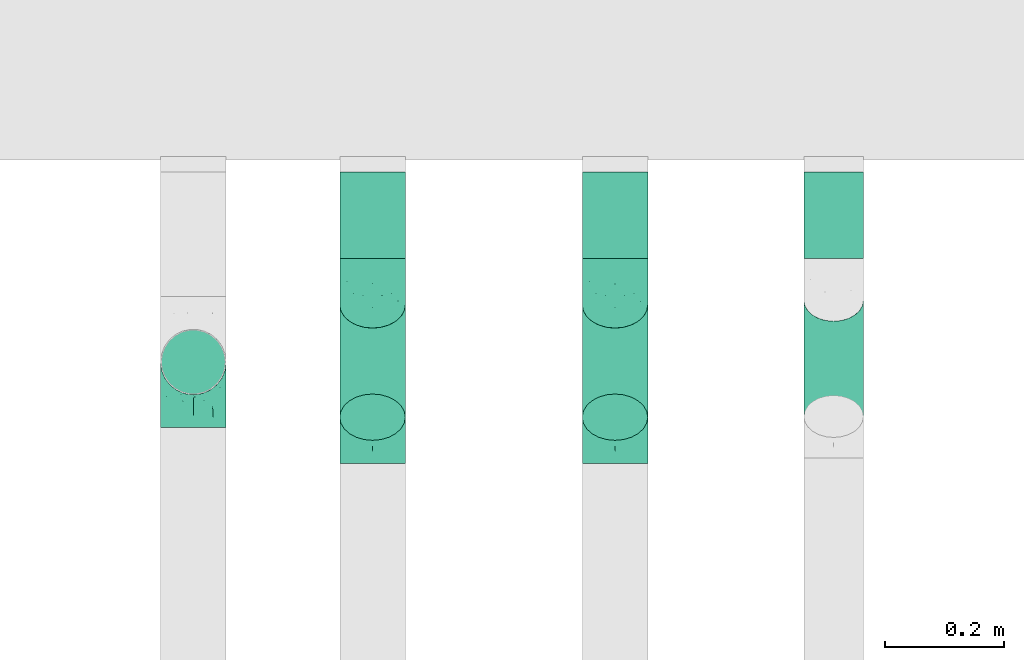
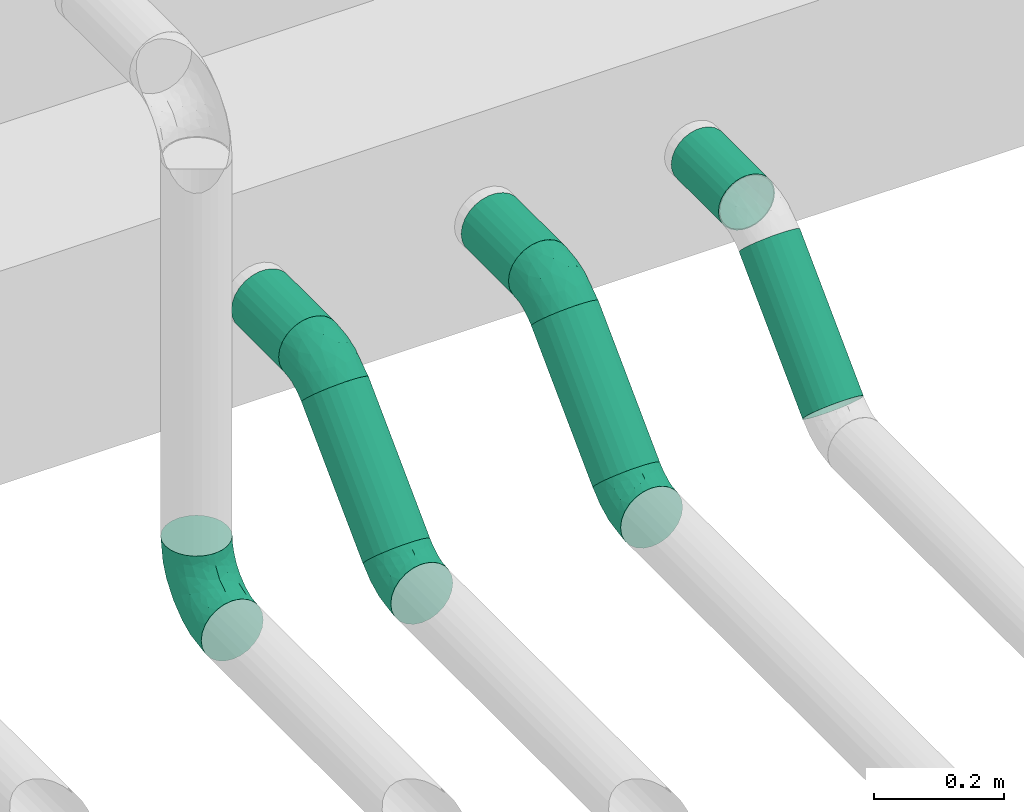
# One storey, part 54 of 91: 6 flow segments, 5 flow fittings.
"""IFC2X3 building model written with IfcOpenShell, lengths in millimetres."""

import ifcopenshell
import ifcopenshell.guid

model = None  # the IFC model being written
_history = None  # IfcOwnerHistory: only IFC2X3 demands one
_inside = {}  # id of a spatial element -> (the spatial element, [elements in it])
_under = {}  # id of a project, library or spatial element -> (it, [spatial elements below it])
_declared = {}  # id of a project -> (the project, [libraries it declares])
_typed = {}  # id of a type object -> (the type object, [elements of that type])
_made_of = {}  # id of a material, layer set ... -> (it, [elements and type objects made of it])


def new_model(schema):
    """Start an empty IFC model of exactly this schema.

    Asked for "IFC4X3", IfcOpenShell would pick the latest addendum, in which some entities
    have other attributes; the version numbers below select the first issue.
    IFC2X3 requires an IfcOwnerHistory on every rooted entity: one is made here for all.
    """
    global model, _history
    if schema == "IFC4X3":
        model = ifcopenshell.file(schema_version=(4, 3, 0, 0))
    else:
        model = ifcopenshell.file(schema=schema)
    _inside.clear()
    _under.clear()
    _declared.clear()
    _typed.clear()
    _made_of.clear()
    _history = None
    if model.schema == "IFC2X3":
        org = make("IfcOrganization", Name="unknown")
        user = make(
            "IfcPersonAndOrganization",
            ThePerson=make("IfcPerson", FamilyName="unknown"),
            TheOrganization=org,
        )
        app = make(
            "IfcApplication",
            ApplicationDeveloper=org,
            Version="unknown",
            ApplicationFullName="unknown",
            ApplicationIdentifier="unknown",
        )
        _history = make(
            "IfcOwnerHistory",
            OwningUser=user,
            OwningApplication=app,
            ChangeAction="ADDED",
            CreationDate=0,
        )
    return model


def make(cls, **values):
    """One entity of the class cls with the attributes given. An attribute that is None is left unset."""
    return model.create_entity(
        cls, **{name: value for name, value in values.items() if value is not None}
    )


def entity(cls, *values):
    """Any entity or typed value of the class cls, its attributes in the order of the schema. None: left unset."""
    e = model.create_entity(cls)
    for i, value in enumerate(values):
        if value is not None:
            e[i] = value
    return e


def rooted(cls, **values):
    """An entity with a GlobalId (a new one), such as an element, a storey or a relation."""
    return make(cls, GlobalId=ifcopenshell.guid.new(), OwnerHistory=_history, **values)


def si_unit(unit_type, name, prefix=None):
    """IfcSIUnit, for example si_unit("LENGTHUNIT", "METRE", prefix="MILLI")."""
    return make("IfcSIUnit", UnitType=unit_type, Prefix=prefix, Name=name)


def converted_unit(unit_type, name, factor, base, dimensions=None, offset=None):
    """IfcConversionBasedUnit, such as the inch: factor (a typed value) times the base unit."""
    return make(
        "IfcConversionBasedUnit"
        if offset is None
        else "IfcConversionBasedUnitWithOffset",
        ConversionOffset=offset,
        Dimensions=None
        if dimensions is None
        else entity("IfcDimensionalExponents", *dimensions),
        UnitType=unit_type,
        Name=name,
        ConversionFactor=make(
            "IfcMeasureWithUnit", ValueComponent=factor, UnitComponent=base
        ),
    )


def derived_unit(unit_type, elements):
    """IfcDerivedUnit: a product of units, each with its exponent."""
    return make(
        "IfcDerivedUnit",
        Elements=[
            make("IfcDerivedUnitElement", Unit=unit, Exponent=power)
            for unit, power in elements
        ],
        UnitType=unit_type,
    )


def assignment(units):
    """IfcUnitAssignment: the units of a project."""
    return None if units is None else make("IfcUnitAssignment", Units=units)


def point(xyz):
    """IfcCartesianPoint."""
    return None if xyz is None else make("IfcCartesianPoint", Coordinates=xyz)


def direction(xyz):
    """IfcDirection."""
    return None if xyz is None else make("IfcDirection", DirectionRatios=xyz)


def frame(location, z_axis=None, x_axis=None):
    """IfcAxis2Placement3D, a coordinate frame: its origin and axes. An axis left out is left unset."""
    return make(
        "IfcAxis2Placement3D",
        Location=point(location),
        Axis=direction(z_axis),
        RefDirection=direction(x_axis),
    )


def frame_2d(location, x_axis=None):
    """IfcAxis2Placement2D, a coordinate frame in the plane: its origin and x axis."""
    return make(
        "IfcAxis2Placement2D", Location=point(location), RefDirection=direction(x_axis)
    )


def origin_with_axes():
    """The frame at (0, 0, 0) with the z axis (0, 0, 1) and the x axis (1, 0, 0) written out."""
    return frame((0.0, 0.0, 0.0), z_axis=(0.0, 0.0, 1.0), x_axis=(1.0, 0.0, 0.0))


def origin_2d_with_axis():
    """The frame at (0, 0) in the plane with the x axis (1, 0) written out."""
    return frame_2d((0.0, 0.0), x_axis=(1.0, 0.0))


def place(relative_to, where):
    """IfcLocalPlacement: puts the frame where relative to a parent placement (None: the world)."""
    return make(
        "IfcLocalPlacement", PlacementRelTo=relative_to, RelativePlacement=where
    )


def context(
    kind, dimensions, precision=None, world=None, true_north=None, identifier=None
):
    """IfcGeometricRepresentationContext, for example the 3D "Model" context."""
    return make(
        "IfcGeometricRepresentationContext",
        ContextIdentifier=identifier,
        ContextType=kind,
        CoordinateSpaceDimension=dimensions,
        Precision=precision,
        WorldCoordinateSystem=world,
        TrueNorth=true_north,
    )


def subcontext(parent, identifier, kind, view, scale=None):
    """IfcGeometricRepresentationSubContext, for example "Body" below "Model"."""
    return make(
        "IfcGeometricRepresentationSubContext",
        ContextIdentifier=identifier,
        ContextType=kind,
        ParentContext=parent,
        TargetScale=scale,
        TargetView=view,
    )


def project(units=None, contexts=None):
    """IfcProject with its units and contexts."""
    return rooted(
        "IfcProject",
        Name="project",
        RepresentationContexts=contexts,
        UnitsInContext=assignment(units),
    )


def spatial(cls, under=None, at=None, **own):
    """A site, building, storey or space (cls), placed at a placement, below another one or the project."""
    s = rooted(cls, ObjectPlacement=at, **own)
    if under is not None:
        _under.setdefault(under.id(), (under, []))[1].append(s)
    return s


def profile(cls, at=None, kind="AREA", **sizes):
    """A parametric profile (cls). Its sizes go by their IFC names, for example OverallWidth=200.0."""
    return make(cls, ProfileType=kind, Position=at, **sizes)


def hollow_circle(**sizes):
    """IfcCircleHollowProfileDef."""
    return profile("IfcCircleHollowProfileDef", **sizes)


def extrude(swept, where, along, depth):
    """IfcExtrudedAreaSolid: the profile swept, set in the frame where, extruded along a direction by depth."""
    return make(
        "IfcExtrudedAreaSolid",
        SweptArea=swept,
        Position=where,
        ExtrudedDirection=direction(along),
        Depth=depth,
    )


def faces_of(points, faces, orient=None, outer=None):
    """IfcFace entities. A face is a list of loops; a loop is a list of indices into points, from 0.

    orient and outer hold one flag for each loop. By default every Orientation is true, the
    first loop of a face is its IfcFaceOuterBound and the others are IfcFaceBound.
    """
    made = []
    for i, loops in enumerate(faces):
        bounds = []
        for j, loop in enumerate(loops):
            is_outer = j == 0 if outer is None else outer[i][j]
            bounds.append(
                make(
                    "IfcFaceOuterBound" if is_outer else "IfcFaceBound",
                    Bound=make("IfcPolyLoop", Polygon=[points[k] for k in loop]),
                    Orientation=True if orient is None else orient[i][j],
                )
            )
        made.append(make("IfcFace", Bounds=bounds))
    return made


def open_shell(faces, orient=None, outer=None):
    """The faces of one IfcOpenShell. surface_model builds it on its shared points."""
    return ("IfcOpenShell", faces, orient, outer)


def surface_model(cls, points, shells):
    """IfcFaceBasedSurfaceModel or IfcShellBasedSurfaceModel (cls): surfaces that need not close."""
    shared = [point(p) for p in points]
    made = [make(c, CfsFaces=faces_of(shared, fs, o, b)) for c, fs, o, b in shells]
    if cls == "IfcFaceBasedSurfaceModel":
        return make(cls, FbsmFaces=made)
    return make(cls, SbsmBoundary=made)


def shape(context_of_items, identifier, shape_type, items):
    """IfcShapeRepresentation: the items that make up one representation, for example the "Body"."""
    return make(
        "IfcShapeRepresentation",
        ContextOfItems=context_of_items,
        RepresentationIdentifier=identifier,
        RepresentationType=shape_type,
        Items=items,
    )


def source(mapping_origin, context_of_items, identifier, shape_type, items):
    """IfcRepresentationMap: a shape defined once, which mapped items show again and again."""
    return make(
        "IfcRepresentationMap",
        MappingOrigin=mapping_origin,
        MappedRepresentation=shape(context_of_items, identifier, shape_type, items),
    )


def transform(
    local_origin,
    x_axis=None,
    y_axis=None,
    z_axis=None,
    scale=None,
    scale2=None,
    scale3=None,
    uniform=True,
):
    """IfcCartesianTransformationOperator3D, or its non-uniform kind. x_axis, y_axis, z_axis: its Axis1, 2, 3."""
    if uniform:
        return make(
            "IfcCartesianTransformationOperator3D",
            Axis1=direction(x_axis),
            Axis2=direction(y_axis),
            LocalOrigin=point(local_origin),
            Scale=scale,
            Axis3=direction(z_axis),
        )
    return make(
        "IfcCartesianTransformationOperator3DnonUniform",
        Axis1=direction(x_axis),
        Axis2=direction(y_axis),
        LocalOrigin=point(local_origin),
        Scale=scale,
        Axis3=direction(z_axis),
        Scale2=scale2,
        Scale3=scale3,
    )


def mapped(mapping_source, mapping_target):
    """IfcMappedItem: shows the shape of a source again, moved by a transform."""
    return make(
        "IfcMappedItem", MappingSource=mapping_source, MappingTarget=mapping_target
    )


def material(Name=None, Category=None):
    """IfcMaterial."""
    return make("IfcMaterial", Name=Name, Category=Category)


def layer(
    of_material, thickness, ventilated=None, Name=None, Category=None, Priority=None
):
    """IfcMaterialLayer: one layer of a wall or slab, of a material (None: an air gap)."""
    return make(
        "IfcMaterialLayer",
        Material=of_material,
        LayerThickness=thickness,
        IsVentilated=ventilated,
        Name=Name,
        Category=Category,
        Priority=Priority,
    )


def layer_set(layers, Name=None):
    """IfcMaterialLayerSet."""
    return make("IfcMaterialLayerSet", MaterialLayers=layers, LayerSetName=Name)


def layer_usage(for_layer_set, set_direction, sense, offset, extent=None):
    """IfcMaterialLayerSetUsage: how a layer set lies in its element."""
    return make(
        "IfcMaterialLayerSetUsage",
        ForLayerSet=for_layer_set,
        LayerSetDirection=set_direction,
        DirectionSense=sense,
        OffsetFromReferenceLine=offset,
        ReferenceExtent=extent,
    )


def made_of(thing, what):
    """Note that an element or type object is made of a material, layer set ...; save() writes the relation."""
    if what is not None:
        _made_of.setdefault(what.id(), (what, []))[1].append(thing)
    return thing


def type_object(cls, material=None, **own):
    """A type object (cls), such as IfcWallType, which elements share."""
    return made_of(rooted(cls, **own), material)


def element(
    cls,
    number,
    at=None,
    inside=None,
    cuts=None,
    type_object=None,
    material=None,
    context=None,
    identifier="Body",
    shape_type=None,
    held_by="IfcProductDefinitionShape",
    body=None,
    shapes=None,
    **own,
):
    """One element of the class cls, such as IfcWall. Its Tag is "e" and its number.

    at: its placement. inside: the storey or other place that contains it. cuts: it is an
    opening in that element (IfcRelVoidsElement). A single representation is given by context,
    identifier, shape_type and body (its items); several are given by shapes. held_by: the class
    of the entity that holds the representations. save() writes the other relations.
    """
    e = rooted(cls, Tag="e%d" % number, ObjectPlacement=at, **own)
    if body is not None:
        shapes = [shape(context, identifier, shape_type, body)]
    if shapes is not None:
        e.Representation = make(held_by, Representations=shapes)
    if inside is not None:
        _inside.setdefault(inside.id(), (inside, []))[1].append(e)
    if cuts is not None:
        rooted(
            "IfcRelVoidsElement", RelatingBuildingElement=cuts, RelatedOpeningElement=e
        )
    if type_object is not None:
        _typed.setdefault(type_object.id(), (type_object, []))[1].append(e)
    return made_of(e, material)


def aggregate(whole, parts):
    """IfcRelAggregates: a whole, such as a stair, and the parts it consists of."""
    return rooted("IfcRelAggregates", RelatingObject=whole, RelatedObjects=parts)


def save(model, path):
    """Write the relations noted so far, then the file.

    IfcRelAggregates (storeys below a building ...), IfcRelContainedInSpatialStructure (elements
    in a storey), IfcRelDefinesByType, IfcRelAssociatesMaterial and IfcRelDeclares: one each for
    every whole, place, type object, material and project.
    """
    for whole, parts in _under.values():
        aggregate(whole, parts)
    for where, things in _inside.values():
        rooted(
            "IfcRelContainedInSpatialStructure",
            RelatedElements=things,
            RelatingStructure=where,
        )
    for kind, things in _typed.values():
        rooted("IfcRelDefinesByType", RelatedObjects=things, RelatingType=kind)
    for what, things in _made_of.values():
        rooted("IfcRelAssociatesMaterial", RelatedObjects=things, RelatingMaterial=what)
    for by, libraries in _declared.values():
        rooted("IfcRelDeclares", RelatingContext=by, RelatedDefinitions=libraries)
    model.write(path)


model = new_model("IFC2X3")

# Units and contexts
model_context = context("Model", 3, precision=1e-05, world=origin_with_axes(), true_north=direction((0.0, 1.0)))
body_context = subcontext(model_context, "Body", "Model", "MODEL_VIEW")
ifc_project = project(units=[si_unit("AREAUNIT", "SQUARE_METRE"), si_unit("VOLUMEUNIT", "CUBIC_METRE", prefix="DECI"), si_unit("TIMEUNIT", "SECOND"), si_unit("THERMODYNAMICTEMPERATUREUNIT", "DEGREE_CELSIUS"), si_unit("PRESSUREUNIT", "PASCAL"), si_unit("MASSUNIT", "GRAM", prefix="KILO"), si_unit("LENGTHUNIT", "METRE", prefix="MILLI"), si_unit("POWERUNIT", "WATT"), si_unit("ELECTRICCURRENTUNIT", "AMPERE"), si_unit("ELECTRICVOLTAGEUNIT", "VOLT"), derived_unit("VOLUMETRICFLOWRATEUNIT", [(si_unit("VOLUMEUNIT", "CUBIC_METRE", prefix="DECI"), 1), (si_unit("TIMEUNIT", "SECOND"), -1)]), derived_unit("LINEARVELOCITYUNIT", [(si_unit("LENGTHUNIT", "METRE"), 1), (si_unit("TIMEUNIT", "SECOND"), -1)]), derived_unit("MASSDENSITYUNIT", [(si_unit("MASSUNIT", "GRAM", prefix="KILO"), 1), (si_unit("VOLUMEUNIT", "CUBIC_METRE"), -1)]), converted_unit("PLANEANGLEUNIT", "DEGREE", entity("IfcRatioMeasure", 0.01745), si_unit("PLANEANGLEUNIT", "RADIAN"), dimensions=[0, 0, 0, 0, 0, 0, 0])], contexts=[model_context])

# Site, building, storey
site_placement = place(None, origin_with_axes())
site = spatial("IfcSite", under=ifc_project, at=site_placement, CompositionType="ELEMENT")
building_placement = place(site_placement, origin_with_axes())
building = spatial("IfcBuilding", under=site, at=building_placement, Name="mc-building", CompositionType="ELEMENT")
storey_placement = place(building_placement, frame((0.0, 0.0, 8700.0), z_axis=(0.0, 0.0, 1.0), x_axis=(1.0, 0.0, 0.0)))
storey = spatial("IfcBuildingStorey", under=building, at=storey_placement, CompositionType="ELEMENT", Elevation=8700.0)

# Flow fitting
duct_fitting_type = type_object("IfcDuctFittingType", Name="BU", PredefinedType="BEND")
shared_shape_1 = source(origin_with_axes(), body_context, "Body", "SurfaceModel", [
    surface_model("IfcShellBasedSurfaceModel", [(-110.0, 0.0, -55.0), (-110.0, -14.23505, -53.12592), (-110.0, 14.23505, -53.12592), (-110.0, 53.12592, 14.23505), (-110.0, 27.5, -47.63139), (-110.0, 38.89087, -38.89087), (-110.0, -55.0, 0.0), (-110.0, -53.12592, 14.23505), (-110.0, -38.89087, -38.89087), (-110.0, -27.5, -47.63139), (-110.0, -53.12592, -14.23505), (-110.0, -47.63139, -27.5), (-110.0, -14.23505, 53.12592), (-110.0, 14.23505, 53.12592), (-110.0, 27.5, 47.63139), (-110.0, -47.63139, 27.5), (-110.0, -38.89087, 38.89087), (-110.0, -27.5, 47.63139), (-110.0, 0.0, 55.0), (-110.0, 55.0, 0.0), (-110.0, 53.12592, -14.23505), (-110.0, 47.63139, -27.5), (-110.0, 47.63139, 27.5), (-110.0, 38.89087, 38.89087), (-14.23505, 110.0, -53.12592), (-55.0, 110.0, 0.0), (0.0, 110.0, -55.0), (-27.5, 110.0, -47.63139), (-38.89087, 110.0, -38.89087), (-47.63139, 110.0, -27.5), (38.89087, 110.0, -38.89087), (53.12592, 110.0, 14.23505), (27.5, 110.0, -47.63139), (14.23505, 110.0, -53.12592), (47.63139, 110.0, -27.5), (53.12592, 110.0, -14.23505), (55.0, 110.0, 0.0), (-53.12592, 110.0, -14.23505), (-53.12592, 110.0, 14.23505), (-47.63139, 110.0, 27.5), (-38.89087, 110.0, 38.89087), (-27.5, 110.0, 47.63139), (0.0, 110.0, 55.0), (-14.23505, 110.0, 53.12592), (38.89087, 110.0, 38.89087), (47.63139, 110.0, 27.5), (27.5, 110.0, 47.63139), (14.23505, 110.0, 53.12592), (-64.21732, 48.68956, 43.63444), (-76.6405, 38.18013, 45.55988), (-60.44912, 32.56953, 51.94617), (-76.00813, 5.38378, 55.0), (-90.15553, 11.94394, 54.09138), (-78.5998, 26.77405, 50.81338), (-70.18771, 18.55163, 54.03432), (-75.55424, 54.2118, 32.41257), (-93.27622, 45.77614, 33.48188), (-96.12334, 22.13664, 50.81337), (-21.00813, 45.34362, 55.0), (-18.36258, 70.48427, 54.04484), (-32.04182, 59.64019, 52.24446), (-63.88653, 74.77858, 17.99134), (-74.66383, 63.08407, 19.92123), (-63.60674, 66.07878, 29.97482), (-99.597, 52.72185, 18.52927), (-93.11138, 56.59448, 10.50359), (-98.21577, 57.34403, 0.0), (-53.42855, 92.60092, 21.04759), (-88.54852, 54.8376, 21.04759), (-11.86161, 90.23965, 54.10313), (-5.38378, 76.00813, 55.0), (-57.34403, 98.21577, 0.0), (-56.64619, 93.12774, 10.22088), (-45.34362, 21.00813, 55.0), (-44.60838, 44.60838, 52.13415), (-92.68484, 35.46673, 43.63443), (-22.25266, 95.40765, 50.81337), (-35.97783, 90.61597, 43.63443), (-43.70931, 69.58671, 44.47149), (-27.23711, 77.39884, 50.81337), (-57.2828, 79.3123, 24.9774), (-58.67786, 84.31125, 16.04456), (-82.93277, 60.36161, 12.91784), (-49.88337, 54.51816, 47.224), (-74.57753, 66.83759, 9.55742), (-45.35812, 94.97281, 33.48188), (-59.18663, 88.95241, 0.0), (-51.517, 78.6292, 33.48188), (-65.14788, 80.03077, 0.0), (-56.45322, 62.06476, 39.63545), (-88.95241, 59.18663, 0.0), (-71.10913, 71.10913, 0.0), (-80.03077, 65.14788, 0.0), (-94.9309, 45.36788, -33.48188), (-93.11358, 56.60141, -10.46614), (-99.64997, 52.79499, -18.30015), (-90.20425, 36.08686, -43.63443), (-79.99933, 46.56772, -37.92748), (-76.00813, 5.38378, -55.0), (-72.75364, 19.68651, -53.60527), (-45.34362, 21.00813, -55.0), (-21.91957, 65.12078, -53.85897), (-5.38378, 76.00813, -55.0), (-21.00813, 45.34362, -55.0), (-35.41876, 92.89265, -43.63443), (-91.10309, 11.02766, -54.21832), (-45.77614, 93.27622, -33.48188), (-90.50474, 23.21022, -50.81337), (-70.92854, 33.31794, -49.51754), (-78.52933, 63.35627, -11.73997), (-24.91508, 84.05606, -50.81337), (-88.78941, 54.74452, -21.04759), (-69.59921, 57.34866, -33.48187), (-73.36422, 62.46673, -22.94182), (-63.49062, 67.59111, -28.46929), (-56.59448, 93.11138, -10.50359), (-54.8376, 88.54852, -21.04759), (-54.10679, 75.85581, -32.31867), (-57.75956, 31.09612, -52.80882), (-52.72185, 99.597, -18.52927), (-12.62913, 89.46304, -53.99097), (-34.46825, 66.46123, -50.04329), (-43.9837, 43.9837, -52.42279), (-65.78527, 72.58348, -17.68796), (-70.34468, 43.65295, -44.21951), (-57.47001, 51.99467, -44.91465), (-60.72547, 82.29174, -12.88567), (-42.34915, 74.24548, -43.63444), (-57.25194, 63.5016, -38.08211), (-80.95344, 53.56991, -29.32027), (-52.32891, 4.55257, -54.0482), (32.52942, 47.13398, -30.48571), (14.88266, 20.92917, -33.7947), (14.95561, 36.05775, -42.26543), (30.24048, 70.09027, -41.7461), (19.3559, 65.35825, -48.00507), (-70.35075, -46.44478, -19.5952), (-47.13398, -32.52942, -30.48571), (-28.49299, -30.5778, -16.4009), (-4.55257, 52.32891, -54.0482), (-22.4954, 22.4954, -53.25347), (-75.47368, -11.22546, -52.60718), (-81.32209, -51.5606, -9.98467), (-80.81763, -41.84862, -32.14655), (-70.09027, -30.24048, -41.7461), (-36.05774, -14.95561, -42.26543), (-9.15831, -10.852, -27.8997), (-65.35825, -19.3559, -48.00507), (11.22546, 75.47368, -52.60718), (3.94376, 43.9333, -50.53315), (-13.39742, 13.39743, -48.13058), (-43.9333, -3.94376, -50.53315), (49.37776, 67.29486, 0.0), (41.8609, 47.82256, -9.92641), (50.20582, 74.51695, -9.9731), (18.93131, 11.7156, -17.56239), (-27.5, -32.89419, 0.0), (-1.23348, -12.25375, -12.18106), (41.84862, 80.81763, -32.14655), (35.70604, 41.31408, -20.38235), (46.44478, 70.35075, -19.5952), (32.89419, 27.5, 0.0), (6.67262, -6.67262, 0.0), (-67.29486, -49.37776, 0.0), (-50.36265, -42.95545, -9.51562), (-5.47251, 5.47251, -39.92906), (-70.35075, -46.44478, 19.5952), (-74.51695, -50.20582, 9.9731), (-41.31407, -35.70604, 20.38235), (-47.13398, -32.52942, 30.48571), (-80.81763, -41.84862, 32.14655), (-4.55257, 52.32891, 54.0482), (11.22546, 75.47368, 52.60718), (-43.9333, -3.94376, 50.53315), (-65.35825, -19.3559, 48.00507), (-36.05774, -14.95561, 42.26543), (-70.09027, -30.24048, 41.7461), (-11.7156, -18.93131, 17.56239), (30.5778, 28.49299, 16.4009), (12.25375, 1.23348, 12.18106), (51.5606, 81.32209, 9.98467), (42.95545, 50.36265, 9.51562), (-75.47368, -11.22546, 52.60718), (-52.32891, 4.55257, 54.0482), (3.94376, 43.9333, 50.53315), (-22.4954, 22.4954, 53.25347), (-13.39742, 13.39743, 48.13058), (10.852, 9.15831, 27.8997), (-20.92916, -14.88266, 33.79469), (-47.82256, -41.8609, 9.92641), (32.52942, 47.13398, 30.48571), (46.44478, 70.35075, 19.5952), (41.84862, 80.81763, 32.14655), (30.24048, 70.09027, 41.7461), (19.3559, 65.35825, 48.00507), (14.95561, 36.05775, 42.26543), (-5.47251, 5.47251, 39.92906)], [open_shell([[[0, 1, 2]], [[2, 3, 4]], [[4, 3, 5]], [[2, 6, 7]], [[8, 6, 9]], [[1, 9, 6]], [[10, 6, 11]], [[8, 11, 6]], [[6, 2, 1]], [[12, 13, 14]], [[15, 2, 7]], [[16, 17, 2]], [[2, 17, 12]], [[12, 18, 13]], [[19, 20, 3]], [[5, 3, 21]], [[20, 21, 3]], [[22, 3, 2]], [[23, 22, 2]], [[12, 14, 2]], [[2, 14, 23]], [[15, 16, 2]], [[24, 25, 26]], [[27, 25, 24]], [[25, 28, 29]], [[28, 25, 27]], [[30, 26, 31]], [[26, 30, 32]], [[32, 33, 26]], [[34, 31, 35]], [[31, 34, 30]], [[35, 31, 36]], [[29, 37, 25]], [[38, 39, 26]], [[39, 40, 26]], [[41, 42, 40]], [[42, 26, 40]], [[42, 41, 43]], [[26, 44, 45]], [[31, 26, 45]], [[26, 46, 44]], [[47, 46, 26]], [[42, 47, 26]], [[25, 38, 26]], [[48, 49, 50]], [[18, 51, 52]], [[53, 54, 50]], [[55, 56, 49]], [[56, 22, 23]], [[13, 57, 14]], [[58, 59, 60]], [[61, 62, 63]], [[3, 64, 65]], [[53, 52, 54]], [[3, 65, 66]], [[67, 39, 38]], [[56, 68, 64]], [[65, 64, 68]], [[69, 59, 70]], [[38, 71, 72]], [[73, 58, 74]], [[75, 49, 56]], [[76, 69, 43]], [[53, 57, 52]], [[77, 78, 79]], [[41, 76, 43]], [[43, 69, 42]], [[55, 68, 56]], [[23, 14, 75]], [[76, 77, 79]], [[80, 67, 81]], [[62, 82, 68]], [[60, 78, 83]], [[62, 84, 82]], [[85, 77, 40]], [[81, 67, 72]], [[86, 72, 71]], [[87, 85, 67]], [[61, 81, 88]], [[77, 41, 40]], [[78, 77, 87]], [[23, 75, 56]], [[83, 89, 48]], [[85, 40, 39]], [[62, 68, 55]], [[89, 87, 63]], [[83, 48, 50]], [[57, 75, 14]], [[49, 75, 53]], [[67, 85, 39]], [[87, 77, 85]], [[63, 62, 55]], [[89, 55, 48]], [[80, 63, 87]], [[66, 65, 90]], [[66, 19, 3]], [[84, 91, 92]], [[92, 90, 82]], [[65, 82, 90]], [[61, 84, 62]], [[92, 82, 84]], [[68, 82, 65]], [[3, 22, 64]], [[56, 64, 22]], [[38, 25, 71]], [[81, 72, 86]], [[38, 72, 67]], [[91, 61, 88]], [[80, 81, 61]], [[63, 80, 61]], [[67, 80, 87]], [[77, 76, 41]], [[79, 59, 69]], [[79, 69, 76]], [[42, 69, 70]], [[60, 59, 79]], [[58, 70, 59]], [[78, 60, 79]], [[58, 60, 74]], [[52, 57, 13]], [[75, 57, 53]], [[18, 52, 13]], [[52, 51, 54]], [[51, 73, 54]], [[50, 73, 74]], [[73, 50, 54]], [[50, 74, 83]], [[60, 83, 74]], [[89, 83, 78]], [[87, 89, 78]], [[55, 89, 63]], [[50, 49, 53]], [[55, 49, 48]], [[81, 86, 88]], [[91, 84, 61]], [[5, 21, 93]], [[90, 94, 66]], [[20, 94, 95]], [[96, 93, 97]], [[98, 99, 100]], [[96, 4, 5]], [[101, 102, 103]], [[28, 27, 104]], [[2, 105, 0]], [[104, 106, 28]], [[99, 105, 107]], [[108, 107, 96]], [[90, 109, 94]], [[107, 2, 4]], [[20, 66, 94]], [[27, 24, 110]], [[109, 111, 94]], [[112, 113, 114]], [[37, 115, 71]], [[116, 106, 117]], [[99, 118, 100]], [[116, 115, 119]], [[37, 119, 115]], [[24, 120, 110]], [[121, 110, 101]], [[119, 106, 116]], [[101, 110, 120]], [[122, 103, 100]], [[117, 123, 116]], [[124, 125, 108]], [[115, 116, 126]], [[106, 29, 28]], [[26, 102, 120]], [[127, 104, 110]], [[97, 124, 96]], [[125, 122, 118]], [[128, 127, 125]], [[96, 5, 93]], [[115, 126, 86]], [[117, 106, 127]], [[111, 113, 129]], [[95, 93, 21]], [[97, 129, 112]], [[110, 104, 27]], [[106, 104, 127]], [[96, 107, 4]], [[99, 107, 108]], [[99, 108, 118]], [[105, 99, 98]], [[112, 114, 128]], [[121, 125, 127]], [[20, 19, 66]], [[109, 90, 92]], [[94, 111, 95]], [[91, 123, 109]], [[129, 113, 112]], [[93, 95, 111]], [[21, 20, 95]], [[71, 115, 86]], [[71, 25, 37]], [[123, 91, 88]], [[126, 116, 123]], [[123, 88, 126]], [[86, 126, 88]], [[37, 29, 119]], [[106, 119, 29]], [[129, 93, 111]], [[124, 112, 125]], [[0, 105, 98]], [[107, 105, 2]], [[125, 118, 108]], [[100, 118, 122]], [[93, 129, 97]], [[113, 111, 109]], [[109, 123, 113]], [[114, 123, 117]], [[123, 114, 113]], [[128, 114, 117]], [[127, 128, 117]], [[112, 128, 125]], [[103, 122, 101]], [[110, 121, 127]], [[101, 122, 121]], [[125, 121, 122]], [[26, 120, 24]], [[101, 120, 102]], [[96, 124, 108]], [[92, 91, 109]], [[112, 124, 97]], [[100, 130, 98]], [[131, 132, 133]], [[32, 134, 135]], [[136, 137, 138]], [[139, 140, 103]], [[98, 141, 0]], [[142, 10, 136]], [[143, 144, 137]], [[6, 10, 142]], [[137, 145, 146]], [[144, 147, 145]], [[143, 136, 11]], [[11, 136, 10]], [[8, 143, 11]], [[148, 149, 139]], [[8, 9, 144]], [[9, 1, 147]], [[130, 141, 98]], [[103, 140, 100]], [[148, 135, 149]], [[150, 151, 140]], [[152, 153, 154]], [[130, 140, 151]], [[148, 26, 33]], [[147, 1, 141]], [[155, 146, 132]], [[156, 138, 157]], [[134, 30, 158]], [[150, 140, 149]], [[158, 30, 34]], [[30, 134, 32]], [[153, 159, 160]], [[131, 160, 159]], [[144, 145, 137]], [[36, 152, 154]], [[146, 138, 137]], [[155, 161, 162]], [[158, 160, 131]], [[133, 149, 135]], [[156, 163, 164]], [[163, 142, 164]], [[139, 103, 102]], [[153, 152, 161]], [[34, 35, 160]], [[162, 157, 155]], [[132, 165, 133]], [[157, 146, 155]], [[140, 130, 100]], [[141, 130, 151]], [[141, 151, 147]], [[141, 1, 0]], [[102, 26, 148]], [[140, 139, 149]], [[102, 148, 139]], [[135, 33, 32]], [[151, 150, 145]], [[9, 147, 144]], [[151, 145, 147]], [[145, 165, 146]], [[135, 148, 33]], [[133, 135, 134]], [[131, 133, 134]], [[133, 165, 150]], [[133, 150, 149]], [[145, 150, 165]], [[132, 131, 159]], [[146, 165, 132]], [[160, 158, 34]], [[134, 158, 131]], [[144, 143, 8]], [[136, 143, 137]], [[155, 153, 161]], [[154, 153, 160]], [[153, 155, 159]], [[132, 159, 155]], [[160, 35, 154]], [[36, 154, 35]], [[164, 136, 138]], [[6, 142, 163]], [[136, 164, 142]], [[156, 164, 138]], [[156, 157, 162]], [[146, 157, 138]], [[15, 7, 166]], [[6, 163, 167]], [[168, 169, 166]], [[166, 169, 170]], [[171, 172, 70]], [[173, 174, 175]], [[17, 176, 174]], [[177, 156, 162]], [[176, 16, 170]], [[170, 16, 15]], [[161, 178, 179]], [[152, 180, 181]], [[182, 173, 183]], [[18, 12, 182]], [[184, 185, 186]], [[183, 185, 73]], [[183, 73, 51]], [[177, 187, 188]], [[189, 168, 166]], [[187, 178, 190]], [[16, 176, 17]], [[161, 152, 181]], [[45, 191, 31]], [[45, 44, 192]], [[192, 191, 45]], [[180, 36, 31]], [[193, 194, 195]], [[46, 47, 194]], [[193, 195, 190]], [[193, 44, 46]], [[172, 42, 70]], [[185, 58, 73]], [[189, 163, 156]], [[163, 189, 167]], [[70, 58, 171]], [[184, 171, 185]], [[169, 188, 175]], [[180, 31, 191]], [[192, 193, 190]], [[191, 190, 178]], [[182, 174, 173]], [[194, 47, 172]], [[190, 195, 187]], [[186, 185, 173]], [[162, 179, 177]], [[188, 196, 175]], [[179, 187, 177]], [[185, 171, 58]], [[172, 171, 184]], [[172, 184, 194]], [[172, 47, 42]], [[51, 18, 182]], [[185, 183, 173]], [[51, 182, 183]], [[174, 12, 17]], [[184, 186, 195]], [[46, 194, 193]], [[184, 195, 194]], [[195, 196, 187]], [[174, 182, 12]], [[175, 174, 176]], [[169, 175, 176]], [[175, 196, 186]], [[175, 186, 173]], [[195, 186, 196]], [[188, 169, 168]], [[187, 196, 188]], [[166, 170, 15]], [[176, 170, 169]], [[193, 192, 44]], [[191, 192, 190]], [[177, 189, 156]], [[167, 189, 166]], [[189, 177, 168]], [[188, 168, 177]], [[166, 7, 167]], [[6, 167, 7]], [[181, 191, 178]], [[36, 180, 152]], [[191, 181, 180]], [[161, 181, 178]], [[161, 179, 162]], [[187, 179, 178]]])]),
])
flow_fitting_placement = place(storey_placement, frame((26486.51753, 2612.35324, 415.0), z_axis=(1.0, 0.0, 0.0), x_axis=(0.0, 1.0, 0.0)))
element("IfcFlowFitting", 1, at=flow_fitting_placement, inside=storey, type_object=duct_fitting_type, Name="BU", context=body_context, shape_type="MappedRepresentation", body=[
    mapped(shared_shape_1, transform((0.0, 0.0, 0.0), scale=1.0)),
])

# Flow segments
ifc_material = material(Name="FZ1")
ifc_layer = layer(ifc_material, 0.0)
ifc_layer_set = layer_set([ifc_layer], Name="FZ1")
ifc_layer_usage = layer_usage(ifc_layer_set, "AXIS1", "POSITIVE", 0.0)
duct_segment_type = type_object("IfcDuctSegmentType", PredefinedType="RIGIDSEGMENT")
shared_shape_2 = source(origin_with_axes(), body_context, "Body", "SweptSolid", [
    extrude(hollow_circle(Radius=55.0, WallThickness=2.0, at=origin_2d_with_axis()), frame((0.0, 0.0, 0.0), z_axis=(1.0, 0.0, 0.0), x_axis=(0.0, 1.0, 0.0)), (0.0, 0.0, 1.0), 266.7),
])
for number, where, z_axis, x_axis in (
    (2, (26787.42189, 2708.27872, 635.78175), (0.0, -0.707107, 0.707107), (0.0, -0.707107, -0.707107)),
    (3, (27194.49649, 2708.27872, 635.78175), (0.0, -0.707107, 0.707107), (0.0, -0.707107, -0.707107)),
):
    element("IfcFlowSegment", number, at=place(storey_placement, frame(where, z_axis=z_axis, x_axis=x_axis)), inside=storey, type_object=duct_segment_type, material=ifc_layer_usage, context=body_context, shape_type="MappedRepresentation", body=[
        mapped(shared_shape_2, transform((0.0, 0.0, 0.0), scale=1.0)),
    ])

# Flow fittings
shared_shape_3 = source(origin_with_axes(), body_context, "Body", "SurfaceModel", [
    surface_model("IfcShellBasedSurfaceModel", [(-45.56349, 0.0, -55.0), (-45.56349, -14.23505, -53.12592), (-45.56349, 14.23505, -53.12592), (-45.56349, 53.12592, 14.23505), (-45.56349, 27.5, -47.63139), (-45.56349, 38.89087, -38.89087), (-45.56349, 47.63139, -27.5), (-45.56349, -55.0, 0.0), (-45.56349, -53.12592, 14.23505), (-45.56349, -38.89087, -38.89087), (-45.56349, -27.5, -47.63139), (-45.56349, -53.12592, -14.23505), (-45.56349, -47.63139, -27.5), (-45.56349, 53.12592, -14.23505), (-45.56349, 47.63139, 27.5), (-45.56349, 38.89087, 38.89087), (-45.56349, -14.23505, 53.12592), (-45.56349, 27.5, 47.63139), (-45.56349, 14.23505, 53.12592), (-45.56349, -47.63139, 27.5), (-45.56349, -38.89087, 38.89087), (-45.56349, -27.5, 47.63139), (-45.56349, 0.0, 55.0), (-45.56349, 55.0, 0.0), (22.15256, 42.28395, -53.12592), (-6.67262, 71.10913, 0.0), (32.21826, 32.21826, -55.0), (12.77282, 51.66369, -47.63139), (-1.46223, 65.89874, -27.5), (4.71825, 59.71825, -38.89087), (59.71825, 4.71825, -38.89087), (69.78395, -5.34744, 14.23505), (51.66369, 12.77282, -47.63139), (42.28395, 22.15256, -53.12592), (65.89874, -1.46223, -27.5), (69.78395, -5.34744, -14.23505), (71.10913, -6.67262, 0.0), (-5.34744, 69.78395, -14.23505), (-5.34744, 69.78395, 14.23505), (-1.46223, 65.89874, 27.5), (4.71825, 59.71825, 38.89087), (32.21826, 32.21826, 55.0), (12.77282, 51.66369, 47.63139), (22.15256, 42.28395, 53.12592), (59.71825, 4.71825, 38.89087), (65.89874, -1.46223, 27.5), (42.28395, 22.15256, 53.12592), (51.66369, 12.77282, 47.63139), (-20.16649, 48.68621, 33.48188), (-26.97111, 35.77503, 43.63444), (-7.30443, 43.73336, 43.63444), (-17.0934, 3.74816, 55.0), (-18.00408, 15.44793, 53.78143), (-30.11707, 22.39897, 50.81337), (-7.49776, 55.63651, 33.48188), (-15.97018, 58.74288, 21.04759), (-31.18231, 52.58712, 21.04759), (-18.35174, 61.03934, 10.51509), (-28.67677, 56.60048, 10.47121), (-34.03924, 44.64267, 33.48188), (-11.52288, 27.81868, 50.81338), (1.19951, 23.16465, 53.81115), (-33.77926, 57.34403, 0.0), (5.4586, 37.12132, 50.81809), (-24.5159, 59.18663, 0.0), (-16.66281, 64.4339, 0.0), (9.43651, 14.73721, 55.0), (-6.22531, 44.36822, -43.63444), (5.4586, 37.12132, -50.81809), (-34.03924, 44.64267, -33.48188), (9.43651, 14.73721, -55.0), (-17.0934, 3.74816, -55.0), (1.19951, 23.16465, -53.81115), (-11.52288, 27.81868, -50.81338), (-30.11707, 22.39897, -50.81337), (-25.75914, 36.08917, -43.63444), (-30.24487, 52.83011, -21.04759), (-20.16649, 48.68621, -33.48188), (-7.49776, 55.63651, -33.48188), (-18.00408, 15.44793, -53.78143), (-28.68366, 56.62226, -10.35271), (-14.15883, 63.53074, -10.87592), (-15.13548, 59.23394, -21.04759), (3.19797, -7.72059, -52.16847), (3.1272, -18.04126, -47.9241), (13.63233, -32.91136, -32.06475), (45.23618, -22.99734, -20.4997), (16.67434, -40.25541, -15.9539), (-17.3935, -51.68264, -9.80849), (-2.85835, -49.37776, 0.0), (48.84421, -24.24609, -9.80849), (-16.38424, -42.76862, -30.85433), (-6.97383, -29.41689, -42.70541), (41.82739, -18.65658, -30.85433), (-15.72523, -48.24839, -20.4997), (29.28945, -13.63928, -42.80781), (26.81493, -3.56603, -49.15704), (36.93651, -32.89419, 0.0), (-15.72523, -48.24839, 20.4997), (-17.3935, -51.68264, 9.80849), (-16.38424, -42.76862, 30.85433), (16.67434, -40.25541, 15.9539), (3.19797, -7.72059, 52.16847), (10.54583, -14.96836, 47.9241), (13.63233, -32.91136, 32.06475), (45.23618, -22.99734, 20.4997), (41.82739, -18.65658, 30.85433), (-11.06635, -30.3552, 42.80781), (25.73213, -15.86964, 42.70541), (-16.43945, -21.48258, 49.15704), (48.84421, -24.24609, 9.80849)], [open_shell([[[0, 1, 2]], [[2, 3, 4]], [[5, 3, 6]], [[4, 3, 5]], [[2, 7, 8]], [[9, 7, 10]], [[1, 10, 7]], [[11, 7, 12]], [[9, 12, 7]], [[7, 2, 1]], [[13, 6, 3]], [[14, 3, 2]], [[15, 14, 2]], [[16, 17, 2]], [[2, 17, 15]], [[16, 18, 17]], [[19, 20, 2]], [[19, 2, 8]], [[20, 21, 2]], [[2, 21, 16]], [[16, 22, 18]], [[23, 13, 3]], [[24, 25, 26]], [[27, 25, 24]], [[28, 25, 29]], [[29, 25, 27]], [[30, 26, 31]], [[26, 30, 32]], [[32, 33, 26]], [[34, 31, 35]], [[31, 34, 30]], [[35, 31, 36]], [[37, 25, 28]], [[26, 38, 39]], [[26, 39, 40]], [[41, 40, 42]], [[26, 40, 41]], [[42, 43, 41]], [[26, 44, 45]], [[31, 26, 45]], [[46, 47, 26]], [[47, 44, 26]], [[46, 26, 41]], [[26, 25, 38]], [[48, 49, 50]], [[22, 51, 52]], [[17, 49, 15]], [[53, 17, 18]], [[49, 17, 53]], [[54, 50, 40]], [[48, 55, 56]], [[55, 57, 58]], [[59, 14, 15]], [[60, 53, 52]], [[50, 49, 60]], [[58, 3, 56]], [[52, 51, 61]], [[62, 23, 3]], [[63, 50, 60]], [[50, 42, 40]], [[3, 58, 62]], [[43, 61, 41]], [[62, 58, 64]], [[48, 59, 49]], [[14, 56, 3]], [[40, 39, 54]], [[57, 64, 58]], [[39, 38, 55]], [[63, 60, 61]], [[54, 55, 48]], [[65, 57, 38]], [[56, 14, 59]], [[38, 25, 65]], [[60, 52, 61]], [[49, 59, 15]], [[55, 58, 56]], [[56, 59, 48]], [[55, 54, 39]], [[50, 54, 48]], [[18, 22, 52]], [[49, 53, 60]], [[18, 52, 53]], [[61, 51, 66]], [[41, 61, 66]], [[63, 61, 43]], [[43, 42, 63]], [[50, 63, 42]], [[38, 57, 55]], [[64, 57, 65]], [[67, 27, 68]], [[69, 5, 6]], [[70, 71, 72]], [[73, 74, 75]], [[76, 77, 69]], [[29, 78, 28]], [[2, 79, 0]], [[13, 23, 62]], [[2, 74, 79]], [[5, 75, 4]], [[77, 78, 67]], [[13, 62, 80]], [[64, 80, 62]], [[81, 80, 64]], [[67, 73, 75]], [[82, 77, 76]], [[81, 64, 65]], [[76, 69, 6]], [[82, 76, 80]], [[24, 72, 68]], [[74, 2, 4]], [[27, 67, 29]], [[26, 70, 72]], [[69, 75, 5]], [[82, 28, 78]], [[72, 71, 79]], [[6, 13, 76]], [[77, 67, 75]], [[13, 80, 76]], [[82, 37, 28]], [[81, 25, 37]], [[82, 81, 37]], [[75, 69, 77]], [[67, 78, 29]], [[82, 78, 77]], [[75, 74, 4]], [[79, 74, 73]], [[79, 73, 72]], [[79, 71, 0]], [[68, 72, 73]], [[26, 72, 24]], [[67, 68, 73]], [[27, 24, 68]], [[80, 81, 82]], [[25, 81, 65]], [[1, 83, 84]], [[85, 86, 87]], [[0, 71, 1]], [[88, 87, 89]], [[90, 86, 35]], [[91, 92, 85]], [[11, 88, 7]], [[30, 34, 93]], [[11, 12, 94]], [[92, 91, 9]], [[85, 94, 91]], [[94, 85, 87]], [[95, 93, 85]], [[85, 92, 95]], [[83, 71, 70]], [[12, 9, 91]], [[70, 26, 33]], [[96, 84, 83]], [[1, 71, 83]], [[95, 96, 32]], [[95, 30, 93]], [[95, 32, 30]], [[97, 89, 87]], [[34, 86, 93]], [[36, 97, 90]], [[94, 88, 11]], [[34, 35, 86]], [[90, 87, 86]], [[93, 86, 85]], [[32, 96, 33]], [[84, 10, 1]], [[33, 83, 70]], [[94, 12, 91]], [[10, 92, 9]], [[87, 88, 94]], [[7, 88, 89]], [[36, 90, 35]], [[87, 90, 97]], [[84, 95, 92]], [[33, 96, 83]], [[95, 84, 96]], [[10, 84, 92]], [[8, 98, 19]], [[7, 89, 99]], [[19, 98, 100]], [[101, 98, 99]], [[46, 102, 103]], [[104, 105, 106]], [[100, 98, 104]], [[107, 104, 108]], [[16, 51, 22]], [[51, 16, 102]], [[107, 20, 100]], [[107, 109, 21]], [[21, 20, 107]], [[103, 47, 46]], [[101, 89, 97]], [[105, 110, 31]], [[44, 47, 108]], [[105, 104, 101]], [[107, 100, 104]], [[31, 110, 36]], [[109, 16, 21]], [[108, 106, 44]], [[105, 45, 106]], [[41, 66, 46]], [[102, 66, 51]], [[46, 66, 102]], [[104, 98, 101]], [[99, 98, 8]], [[106, 108, 104]], [[110, 101, 97]], [[45, 44, 106]], [[105, 31, 45]], [[20, 19, 100]], [[109, 103, 102]], [[101, 110, 105]], [[36, 110, 97]], [[7, 99, 8]], [[101, 99, 89]], [[103, 107, 108]], [[16, 109, 102]], [[107, 103, 109]], [[47, 103, 108]]])]),
])
for number, where, z_axis, x_axis, name in (
    (4, (26787.42189, 2740.49698, 668.0), (-1.0, 0.0, 0.0), (0.0, 0.707107, 0.707107), "BU"),
    (5, (26787.42189, 2487.49698, 415.0), (1.0, 0.0, 0.0), (0.0, 1.0, 0.0), "BU"),
    (6, (27194.49649, 2740.49698, 668.0), (-1.0, 0.0, 0.0), (0.0, 0.707107, 0.707107), "BU"),
    (7, (27194.49649, 2487.49698, 415.0), (1.0, 0.0, 0.0), (0.0, 1.0, 0.0), "BU"),
):
    element("IfcFlowFitting", number, at=place(storey_placement, frame(where, z_axis=z_axis, x_axis=x_axis)), inside=storey, type_object=duct_fitting_type, Name=name, context=body_context, shape_type="MappedRepresentation", body=[
        mapped(shared_shape_3, transform((0.0, 0.0, 0.0), scale=1.0)),
    ])

# Flow segments
shared_shape_4 = source(origin_with_axes(), body_context, "Body", "SweptSolid", [
    extrude(hollow_circle(Radius=50.0, WallThickness=2.0, at=origin_2d_with_axis()), frame((0.0, 0.0, 0.0), z_axis=(1.0, 0.0, 0.0), x_axis=(0.0, 1.0, 0.0)), (0.0, 0.0, 1.0), 275.8),
])
flow_segment_1_placement = place(storey_placement, frame((27561.56962, 2716.06909, 639.00862), z_axis=(0.0, -0.707107, 0.707107), x_axis=(0.0, -0.707107, -0.707107)))
element("IfcFlowSegment", 8, at=flow_segment_1_placement, inside=storey, type_object=duct_segment_type, material=ifc_layer_usage, context=body_context, shape_type="MappedRepresentation", body=[
    mapped(shared_shape_4, transform((0.0, 0.0, 0.0), scale=1.0)),
])
shared_shape_5 = source(origin_with_axes(), body_context, "Body", "SweptSolid", [
    extrude(hollow_circle(Radius=55.0, WallThickness=2.0, at=origin_2d_with_axis()), frame((0.0, 0.0, 0.0), z_axis=(1.0, 0.0, 0.0), x_axis=(0.0, 1.0, 0.0)), (0.0, 0.0, 1.0), 145.1),
])
for number, where, z_axis, x_axis in (
    (9, (26787.42189, 2931.20513, 668.0), (0.0, 0.0, 1.0), (0.0, -1.0, 0.0)),
    (10, (27194.49649, 2931.20513, 668.0), (0.0, 0.0, 1.0), (0.0, -1.0, 0.0)),
):
    element("IfcFlowSegment", number, at=place(storey_placement, frame(where, z_axis=z_axis, x_axis=x_axis)), inside=storey, type_object=duct_segment_type, material=ifc_layer_usage, context=body_context, shape_type="MappedRepresentation", body=[
        mapped(shared_shape_5, transform((0.0, 0.0, 0.0), scale=1.0)),
    ])
shared_shape_6 = source(origin_with_axes(), body_context, "Body", "SweptSolid", [
    extrude(hollow_circle(Radius=50.0, WallThickness=2.0, at=origin_2d_with_axis()), frame((0.0, 0.0, 0.0), z_axis=(1.0, 0.0, 0.0), x_axis=(0.0, 1.0, 0.0)), (0.0, 0.0, 1.0), 145.1),
])
flow_segment_2_placement = place(storey_placement, frame((27561.56962, 2931.20513, 668.0), z_axis=(0.0, 0.0, 1.0), x_axis=(0.0, -1.0, 0.0)))
element("IfcFlowSegment", 11, at=flow_segment_2_placement, inside=storey, type_object=duct_segment_type, material=ifc_layer_usage, context=body_context, shape_type="MappedRepresentation", body=[
    mapped(shared_shape_6, transform((0.0, 0.0, 0.0), scale=1.0)),
])

save(model, "model.ifc")
